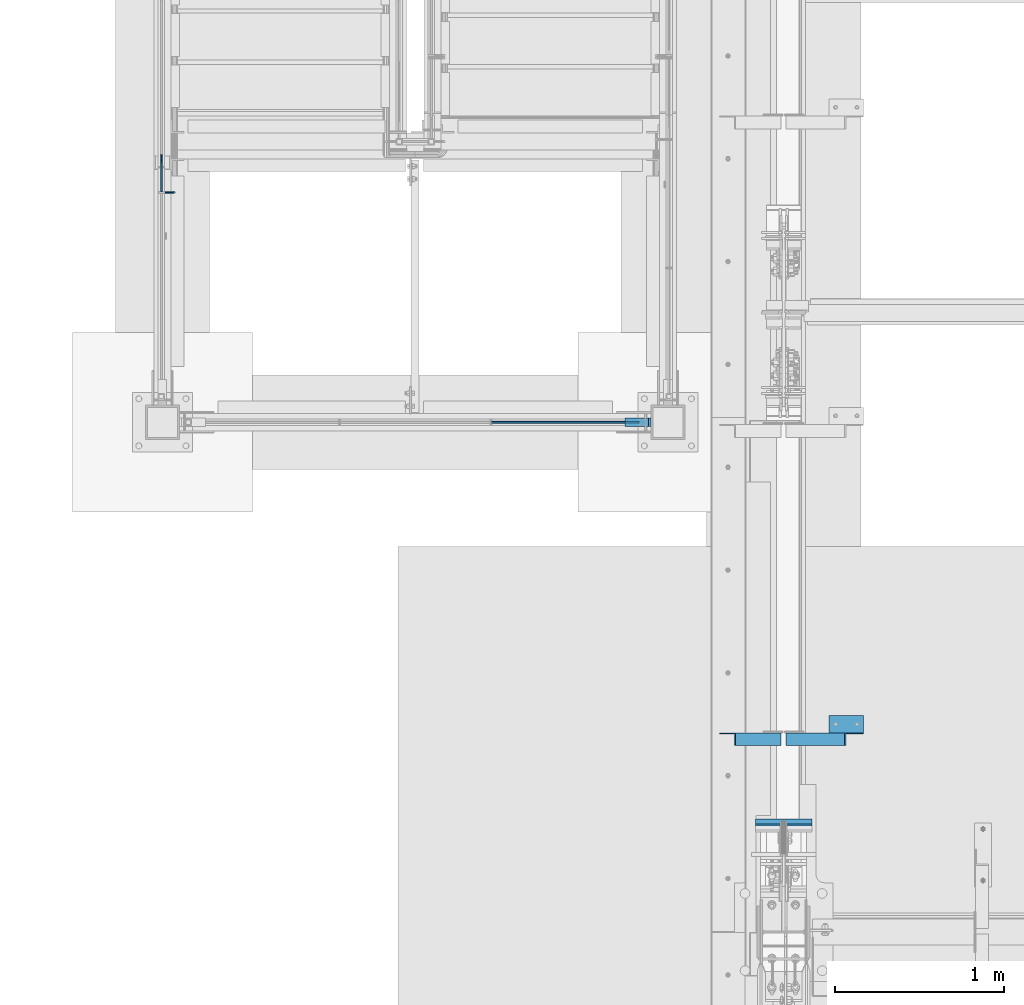
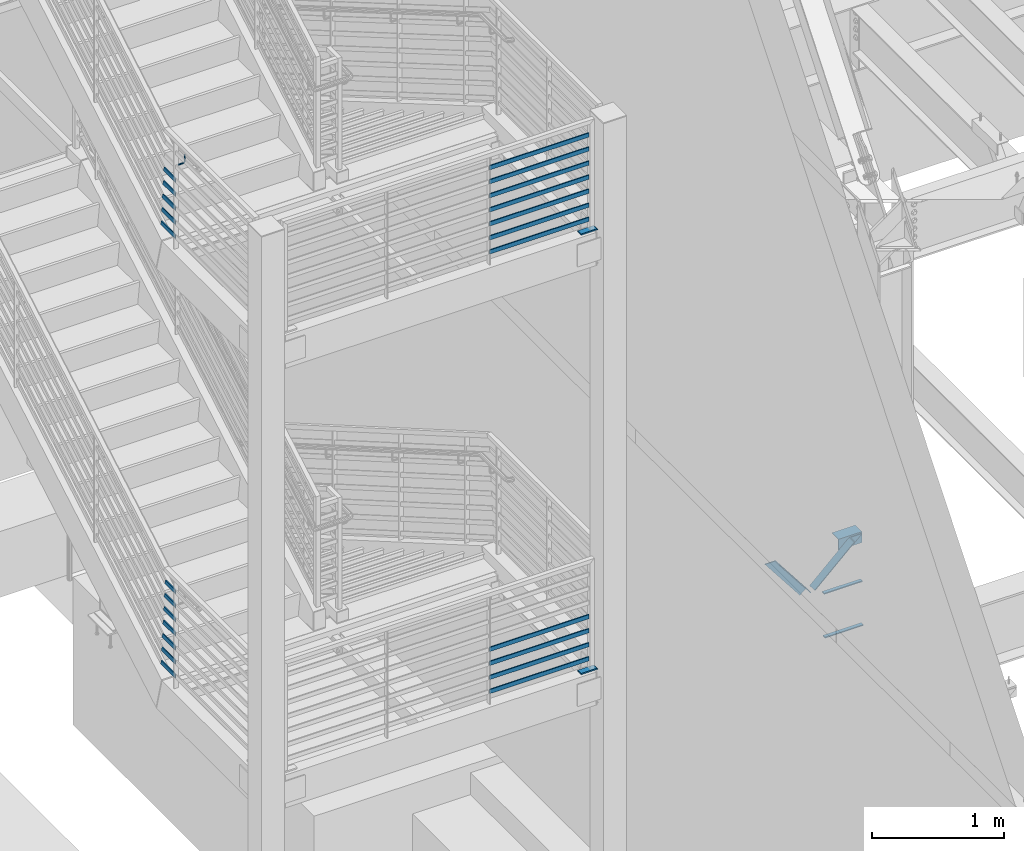
# One storey, part 832 of 1179: 29 beams, 2 members, 10 elements without a shape of their own.
"""IFC2X3 building model written with IfcOpenShell, lengths in millimetres."""

from ifc_helpers import new_model, si_unit, frame, origin_with_axes, place, context, subcontext, project, spatial, faceted_brep, material, type_object, element, aggregate, save


model = new_model("IFC2X3")

# Units and contexts
model_context = context("Model", 3, precision=1e-05, world=origin_with_axes())
body_context = subcontext(model_context, "Body", "Model", "MODEL_VIEW")
ifc_project = project(units=[si_unit("LENGTHUNIT", "METRE", prefix="MILLI"), si_unit("AREAUNIT", "SQUARE_METRE"), si_unit("VOLUMEUNIT", "CUBIC_METRE"), si_unit("MASSUNIT", "GRAM", prefix="KILO"), si_unit("TIMEUNIT", "SECOND"), si_unit("PLANEANGLEUNIT", "RADIAN"), si_unit("SOLIDANGLEUNIT", "STERADIAN"), si_unit("THERMODYNAMICTEMPERATUREUNIT", "DEGREE_CELSIUS"), si_unit("LUMINOUSINTENSITYUNIT", "LUMEN")], contexts=[model_context])

# Site, building, storey
site_placement = place(None, origin_with_axes())
site = spatial("IfcSite", under=ifc_project, at=site_placement, CompositionType="ELEMENT")
building_placement = place(site_placement, origin_with_axes())
building = spatial("IfcBuilding", under=site, at=building_placement, Name="Undefined", CompositionType="ELEMENT")
storey_placement = place(building_placement, origin_with_axes())
storey = spatial("IfcBuildingStorey", under=building, at=storey_placement, Name="Undefined", CompositionType="ELEMENT", Elevation=0.0)

# Assembly, beam
assembly_1_placement = place(storey_placement, origin_with_axes())
assembly_1 = element("IfcElementAssembly", 1, at=assembly_1_placement, inside=storey, Name="PLATE", AssemblyPlace="NOTDEFINED", PredefinedType="RIGID_FRAME")
ifc_material_1 = material(Name="STEEL/A572-GR.50")
beam_type_1 = type_object("IfcBeamType", PredefinedType="NOTDEFINED")
beam_1_placement = place(assembly_1_placement, frame((-507.999999999998, 30073.6, 2174.875), z_axis=(0.0, 1.0, 0.0), x_axis=(1.0, 0.0, 0.0)))
beam_1 = element("IfcBeam", 2, at=beam_1_placement, type_object=beam_type_1, material=ifc_material_1, Name="PLATE", context=body_context, shape_type="Brep", body=[
    faceted_brep([(152.399999999998, 6.35000000000036, 25.4000000000015), (139.699999999998, -6.35000000000036, 25.4000000000015), (139.699999999998, -6.35000000000036, -25.4000000000015), (152.399999999998, 6.35000000000036, -25.4000000000015), (0.0, -6.35000000000036, -25.4000000000015), (0.0, -6.35000000000036, 25.4000000000015), (0.0, 6.35000000000036, 25.4000000000015), (0.0, 6.35000000000036, -25.4000000000015)], [[[0, 1, 2, 3]], [[4, 5, 6, 7]], [[7, 6, 0, 3]], [[4, 7, 3, 2]], [[5, 4, 2, 1]], [[6, 5, 1, 0]]]),
])
aggregate(assembly_1, [beam_1])

assembly_2_placement = place(storey_placement, origin_with_axes())
assembly_2 = element("IfcElementAssembly", 3, at=assembly_2_placement, inside=storey, Name="PLATE", AssemblyPlace="NOTDEFINED", PredefinedType="RIGID_FRAME")
beam_2_placement = place(assembly_2_placement, frame((-507.999999999998, 30073.6, 6248.4), z_axis=(0.0, 1.0, 0.0), x_axis=(1.0, 0.0, 0.0)))
beam_2 = element("IfcBeam", 4, at=beam_2_placement, type_object=beam_type_1, material=ifc_material_1, Name="PLATE", context=body_context, shape_type="Brep", body=[
    faceted_brep([(152.399999999998, 6.35000000000036, 25.4000000000015), (139.699999999998, -6.35000000000036, 25.4000000000015), (139.699999999998, -6.35000000000036, -25.4000000000015), (152.399999999998, 6.35000000000036, -25.4000000000015), (0.0, -6.35000000000036, -25.4000000000015), (0.0, -6.35000000000036, 25.4000000000015), (0.0, 6.35000000000036, 25.4000000000015), (0.0, 6.35000000000036, -25.4000000000015)], [[[0, 1, 2, 3]], [[4, 5, 6, 7]], [[7, 6, 0, 3]], [[4, 7, 3, 2]], [[5, 4, 2, 1]], [[6, 5, 1, 0]]]),
])
aggregate(assembly_2, [beam_2])

assembly_3_placement = place(storey_placement, origin_with_axes())
assembly_3 = element("IfcElementAssembly", 5, at=assembly_3_placement, inside=storey, Name="GUARDRAIL", AssemblyPlace="NOTDEFINED", PredefinedType="RIGID_FRAME")
ifc_material_2 = material(Name="STEEL/A36")
beam_type_2 = type_object("IfcBeamType", PredefinedType="NOTDEFINED")
beam_3_placement = place(assembly_3_placement, frame((-3238.5000060417, 31436.7333342762, 7010.39999999552), z_axis=(0.0, 0.0, 1.0), x_axis=(1.0, 0.0, 0.0)))
beam_3 = element("IfcBeam", 6, at=beam_3_placement, type_object=beam_type_2, material=ifc_material_2, Name="BRACKET", context=body_context, shape_type="Brep", body=[
    faceted_brep([(0.0, -4.49012806053361, 4.49012806053452), (0.0, 0.0, 6.34999999999991), (0.0, 4.49012806053361, 4.49012806053452), (0.0, 6.34999999999854, 0.0), (0.0, 4.49012806053361, -4.49012806053452), (0.0, 0.0, -6.34999999999991), (0.0, -4.49012806053361, -4.49012806053452), (0.0, -6.34999999999854, 0.0), (44.4500031699827, 0.0, -6.34999999999991), (44.4500031699827, -4.49012806053361, -4.49012806053452), (44.4500031699827, -6.34999999999854, 2.19733919948339e-09), (44.4500031699827, -4.49012806053361, 4.49012806053452), (44.4500031699827, 0.0, 6.34999999999991), (44.4500031699827, 4.49012806053361, 4.49012806053452), (44.4500031699827, 6.34999999999854, 0.0), (44.4500031699827, 4.49012806053361, -4.49012806053452), (53.0450671075391, 4.4901280570557, -2.18708762112465), (53.97500307462, -4.32919478043914e-09, -3.79778396764459), (53.0450671022344, -4.49012806401151, -2.1870876194389), (50.8000030708674, -6.35000000142099, 1.70147734757802), (48.5549390416977, -4.4901280599006, 5.59004231389645), (47.6250030746168, 1.48793333210051e-09, 7.20073866041594), (48.5549390470023, 4.49012806117025, 5.5900423122107), (50.8000030783693, 6.34999999857973, 1.70147734519378), (55.4485256393576, 6.34999999469437, 6.34999990618098), (59.337090604122, 4.49012805180246, 4.10493587545716), (51.5599606707875, 4.49012805866005, 8.59506393599531), (49.9492643188311, -4.54747350886464e-10, 9.52499990463002), (51.5599606615996, -4.4901280624108, 8.59506393379797), (55.4485256263639, -6.35000000530636, 6.34999990307369), (59.337090594938, -4.49012806926839, 4.10493587326664), (60.9477869468905, -1.0153598850593e-08, 3.17499990462466), (61.6401310450869, 4.49012804462109, 12.6999998130159), (63.5000029792477, -1.81098585017025e-08, 12.6999998092651), (57.1500029867496, 6.3499999893902, 12.6999998145698), (52.6598749240178, 4.49012805522943, 12.6999998130159), (50.8000029792477, -3.10683390125632e-09, 12.6999998092651), (52.6598749134085, -4.49012806583778, 12.6999998055144), (57.1500029739432, -6.35000001061053, 12.6999998039605), (61.6401310344776, -4.49012807644976, 12.6999998055144), (63.5000029792478, -6.94672053214163e-08, 76.1999999999989), (61.6401310356729, -4.49012812829824, 76.1999999999989), (57.1500029739432, -6.3500000636559, 76.1999999999989), (52.6598749146037, -4.49012812008004, 76.1999999999989), (50.8000029792478, -5.78438630327582e-08, 76.1999999999989), (52.6598749228227, 4.49012800098717, 76.1999999999989), (57.1500029850595, 6.34999993634483, 76.1999999999989), (61.6401310438919, 4.49012799276898, 76.1999999999989)], [[[0, 1, 2, 3, 4, 5, 6, 7]], [[6, 5, 8, 9]], [[7, 6, 9, 10]], [[0, 7, 10, 11]], [[1, 0, 11, 12]], [[2, 1, 12, 13]], [[3, 2, 13, 14]], [[4, 3, 14, 15]], [[5, 4, 15, 8]], [[8, 15, 16, 17]], [[9, 8, 17, 18]], [[10, 9, 18, 19]], [[11, 10, 19, 20]], [[12, 11, 20, 21]], [[13, 12, 21, 22]], [[14, 13, 22, 23]], [[15, 14, 23, 16]], [[23, 24, 25, 16]], [[22, 26, 24, 23]], [[21, 27, 26, 22]], [[20, 28, 27, 21]], [[19, 29, 28, 20]], [[18, 30, 29, 19]], [[17, 31, 30, 18]], [[16, 25, 31, 17]], [[25, 32, 33, 31]], [[24, 34, 32, 25]], [[26, 35, 34, 24]], [[27, 36, 35, 26]], [[28, 37, 36, 27]], [[29, 38, 37, 28]], [[30, 39, 38, 29]], [[31, 33, 39, 30]], [[39, 33, 40, 41]], [[38, 39, 41, 42]], [[37, 38, 42, 43]], [[36, 37, 43, 44]], [[35, 36, 44, 45]], [[34, 35, 45, 46]], [[32, 34, 46, 47]], [[33, 32, 47, 40]], [[46, 45, 44, 43, 42, 41, 40, 47]]]),
])

# Assembly, beams
assembly_4_placement = place(storey_placement, origin_with_axes())
assembly_4 = element("IfcElementAssembly", 7, at=assembly_4_placement, inside=storey, Name="GUARDRAIL", AssemblyPlace="NOTDEFINED", PredefinedType="RIGID_FRAME")
beam_type_3 = type_object("IfcBeamType", PredefinedType="NOTDEFINED")
beam_4_placement = place(assembly_4_placement, frame((-1303.86666666667, 30073.6, 6350.05291795201), z_axis=(0.0, 0.0, 1.0), x_axis=(1.0, 0.0, 0.0)))
beam_4 = element("IfcBeam", 8, at=beam_4_placement, type_object=beam_type_3, material=ifc_material_2, Name="PLATE", context=body_context, shape_type="Brep", body=[
    faceted_brep([(4.76250000197615, 4.76249999999999, -19.0500000000002), (4.76250000197615, 4.76249999999999, 19.0500000000002), (878.416667431667, 4.76249999999709, 19.0499999999993), (878.416667431667, 4.76249999999709, -19.0499999999993), (4.76250000197615, -4.76249999999999, 19.0500000000002), (878.416667431667, -4.76249999999709, 19.0499999999993), (4.76250000197615, -4.76249999999999, -19.0500000000002), (878.416667431667, -4.76249999999709, -19.0499999999993)], [[[0, 1, 2, 3]], [[1, 4, 5, 2]], [[4, 6, 7, 5]], [[6, 0, 3, 7]], [[5, 7, 3, 2]], [[6, 4, 1, 0]]]),
])
beam_5_placement = place(assembly_4_placement, frame((-1303.86666666667, 30073.6, 6480.22791840516), z_axis=(0.0, 0.0, 1.0), x_axis=(1.0, 0.0, 0.0)))
beam_5 = element("IfcBeam", 9, at=beam_5_placement, type_object=beam_type_3, material=ifc_material_2, Name="PLATE", context=body_context, shape_type="Brep", body=[
    faceted_brep([(4.76250000197615, 4.76249999999999, -19.0500000000002), (4.76250000197615, 4.76249999999999, 19.0500000000002), (878.416667431667, 4.76249999999709, 19.0499999999993), (878.416667431667, 4.76249999999709, -19.0499999999993), (4.76250000197615, -4.76249999999999, 19.0500000000002), (878.416667431667, -4.76249999999709, 19.0499999999993), (4.76250000197615, -4.76249999999999, -19.0500000000002), (878.416667431667, -4.76249999999709, -19.0499999999993)], [[[0, 1, 2, 3]], [[1, 4, 5, 2]], [[4, 6, 7, 5]], [[6, 0, 3, 7]], [[5, 7, 3, 2]], [[6, 4, 1, 0]]]),
])
beam_6_placement = place(assembly_4_placement, frame((-1303.86666666667, 30073.6, 6610.40291796448), z_axis=(0.0, 0.0, 1.0), x_axis=(1.0, 0.0, 0.0)))
beam_6 = element("IfcBeam", 10, at=beam_6_placement, type_object=beam_type_3, material=ifc_material_2, Name="PLATE", context=body_context, shape_type="Brep", body=[
    faceted_brep([(4.76250000197615, 4.76249999999999, -19.0500000000002), (4.76250000197615, 4.76249999999999, 19.0500000000002), (878.416667431667, 4.76249999999709, 19.0499999999993), (878.416667431667, 4.76249999999709, -19.0499999999993), (4.76250000197615, -4.76249999999999, 19.0500000000002), (878.416667431667, -4.76249999999709, 19.0499999999993), (4.76250000197615, -4.76249999999999, -19.0500000000002), (878.416667431667, -4.76249999999709, -19.0499999999993)], [[[0, 1, 2, 3]], [[1, 4, 5, 2]], [[4, 6, 7, 5]], [[6, 0, 3, 7]], [[5, 7, 3, 2]], [[6, 4, 1, 0]]]),
])
beam_7_placement = place(assembly_4_placement, frame((-1303.86666666667, 30073.6, 6740.57791897761), z_axis=(0.0, 0.0, 1.0), x_axis=(1.0, 0.0, 0.0)))
beam_7 = element("IfcBeam", 11, at=beam_7_placement, type_object=beam_type_3, material=ifc_material_2, Name="PLATE", context=body_context, shape_type="Brep", body=[
    faceted_brep([(4.76250000197615, 4.76249999999999, -19.0500000000002), (4.76250000197615, 4.76249999999999, 19.0500000000002), (878.416667431667, 4.76249999999709, 19.0499999999993), (878.416667431667, 4.76249999999709, -19.0499999999993), (4.76250000197615, -4.76249999999999, 19.0500000000002), (878.416667431667, -4.76249999999709, 19.0499999999993), (4.76250000197615, -4.76249999999999, -19.0500000000002), (878.416667431667, -4.76249999999709, -19.0499999999993)], [[[0, 1, 2, 3]], [[1, 4, 5, 2]], [[4, 6, 7, 5]], [[6, 0, 3, 7]], [[5, 7, 3, 2]], [[6, 4, 1, 0]]]),
])
beam_8_placement = place(assembly_4_placement, frame((-1303.86666666667, 30073.6, 6870.75291897588), z_axis=(0.0, 0.0, 1.0), x_axis=(1.0, 0.0, 0.0)))
beam_8 = element("IfcBeam", 12, at=beam_8_placement, type_object=beam_type_3, material=ifc_material_2, Name="PLATE", context=body_context, shape_type="Brep", body=[
    faceted_brep([(4.76250000197615, 4.76249999999999, -19.0500000000002), (4.76250000197615, 4.76249999999999, 19.0500000000002), (878.416667431667, 4.76249999999709, 19.0499999999993), (878.416667431667, 4.76249999999709, -19.0499999999993), (4.76250000197615, -4.76249999999999, 19.0500000000002), (878.416667431667, -4.76249999999709, 19.0499999999993), (4.76250000197615, -4.76249999999999, -19.0500000000002), (878.416667431667, -4.76249999999709, -19.0499999999993)], [[[0, 1, 2, 3]], [[1, 4, 5, 2]], [[4, 6, 7, 5]], [[6, 0, 3, 7]], [[5, 7, 3, 2]], [[6, 4, 1, 0]]]),
])
beam_9_placement = place(assembly_4_placement, frame((-1303.86666666667, 30073.6, 7000.92791897937), z_axis=(0.0, 0.0, 1.0), x_axis=(1.0, 0.0, 0.0)))
beam_9 = element("IfcBeam", 13, at=beam_9_placement, type_object=beam_type_3, material=ifc_material_2, Name="PLATE", context=body_context, shape_type="Brep", body=[
    faceted_brep([(4.76250000197615, 4.76249999999999, -19.0500000000002), (4.76250000197615, 4.76249999999999, 19.0500000000002), (878.416667431667, 4.76249999999709, 19.0499999999993), (878.416667431667, 4.76249999999709, -19.0499999999993), (4.76250000197615, -4.76249999999999, 19.0500000000002), (878.416667431667, -4.76249999999709, 19.0499999999993), (4.76250000197615, -4.76249999999999, -19.0500000000002), (878.416667431667, -4.76249999999709, -19.0499999999993)], [[[0, 1, 2, 3]], [[1, 4, 5, 2]], [[4, 6, 7, 5]], [[6, 0, 3, 7]], [[5, 7, 3, 2]], [[6, 4, 1, 0]]]),
])
beam_10_placement = place(assembly_4_placement, frame((-1303.86666666667, 30073.6, 7131.10291897937), z_axis=(0.0, 0.0, 1.0), x_axis=(1.0, 0.0, 0.0)))
beam_10 = element("IfcBeam", 14, at=beam_10_placement, type_object=beam_type_3, material=ifc_material_2, Name="PLATE", context=body_context, shape_type="Brep", body=[
    faceted_brep([(4.76250000197615, 4.76249999999999, -19.0500000000002), (4.76250000197615, 4.76249999999999, 19.0500000000002), (878.416667431667, 4.76249999999709, 19.0499999999993), (878.416667431667, 4.76249999999709, -19.0499999999993), (4.76250000197615, -4.76249999999999, 19.0500000000002), (878.416667431667, -4.76249999999709, 19.0499999999993), (4.76250000197615, -4.76249999999999, -19.0500000000002), (878.416667431667, -4.76249999999709, -19.0499999999993)], [[[0, 1, 2, 3]], [[1, 4, 5, 2]], [[4, 6, 7, 5]], [[6, 0, 3, 7]], [[5, 7, 3, 2]], [[6, 4, 1, 0]]]),
])
aggregate(assembly_4, [beam_4, beam_5, beam_6, beam_7, beam_8, beam_9, beam_10])

# Beam
beam_11_placement = place(assembly_3_placement, frame((-3257.54999923555, 31660.4888003087, 6349.99999993336), z_axis=(0.0, 0.0, 1.0), x_axis=(0.0, -1.0, 0.0)))
beam_11 = element("IfcBeam", 15, at=beam_11_placement, type_object=beam_type_3, material=ifc_material_2, Name="PLATE", context=body_context, shape_type="Brep", body=[
    faceted_brep([(-1.58237177445335, 4.76249999999982, -19.0500000000002), (8.71746487778728, 4.76249999999982, 19.0500000000002), (218.992966975384, 4.76249999999982, 19.0500000000002), (218.992966975384, 4.76249999999982, -19.0500000000002), (8.71746487778728, -4.76249999999982, 19.0500000000002), (218.992966975384, -4.76249999999982, 19.0500000000002), (-1.58237177445335, -4.76249999999982, -19.0500000000002), (218.992966975384, -4.76249999999982, -19.0500000000002)], [[[0, 1, 2, 3]], [[1, 4, 5, 2]], [[4, 6, 7, 5]], [[6, 0, 3, 7]], [[5, 7, 3, 2]], [[6, 4, 1, 0]]]),
])

beam_12_placement = place(assembly_3_placement, frame((-3257.54999923555, 31649.6033755532, 6480.1252855965), z_axis=(0.0, 0.0, 1.0), x_axis=(0.0, -1.0, 0.0)))
beam_12 = element("IfcBeam", 16, at=beam_12_placement, type_object=beam_type_3, material=ifc_material_2, Name="PLATE", context=body_context, shape_type="Brep", body=[
    faceted_brep([(-2.08273084649409, 4.76249999999982, -19.0500000000002), (8.21710580574654, 4.76249999999982, 19.0500000000002), (208.107542219892, 4.76249999999982, 19.0500000000002), (208.107542219892, 4.76249999999982, -19.0500000000002), (8.21710580574654, -4.76249999999982, 19.0500000000002), (208.107542219892, -4.76249999999982, 19.0500000000002), (-2.08273084649409, -4.76249999999982, -19.0500000000002), (208.107542219892, -4.76249999999982, -19.0500000000002)], [[[0, 1, 2, 3]], [[1, 4, 5, 2]], [[4, 6, 7, 5]], [[6, 0, 3, 7]], [[5, 7, 3, 2]], [[6, 4, 1, 0]]]),
])

beam_13_placement = place(assembly_3_placement, frame((-3257.54999923555, 31638.7169688553, 6610.31317642902), z_axis=(0.0, 0.0, 1.0), x_axis=(0.0, -1.0, 0.0)))
beam_13 = element("IfcBeam", 17, at=beam_13_placement, type_object=beam_type_3, material=ifc_material_2, Name="PLATE", context=body_context, shape_type="Brep", body=[
    faceted_brep([(-2.69140062553925, 4.76249999999982, -19.0500000000002), (7.60843602670138, 4.76249999999982, 19.0500000000002), (197.221135521973, 4.76249999999982, 19.0500000000002), (197.221135521973, 4.76249999999982, -19.0500000000002), (7.60843602670138, -4.76249999999982, 19.0500000000002), (197.221135521973, -4.76249999999982, 19.0500000000002), (-2.69140062553925, -4.76249999999982, -19.0500000000002), (197.221135521973, -4.76249999999982, -19.0500000000002)], [[[0, 1, 2, 3]], [[1, 4, 5, 2]], [[4, 6, 7, 5]], [[6, 0, 3, 7]], [[5, 7, 3, 2]], [[6, 4, 1, 0]]]),
])

beam_14_placement = place(assembly_3_placement, frame((-3257.54999923555, 31627.8305624375, 6740.50828692898), z_axis=(0.0, 0.0, 1.0), x_axis=(0.0, -1.0, 0.0)))
beam_14 = element("IfcBeam", 18, at=beam_14_placement, type_object=beam_type_3, material=ifc_material_2, Name="PLATE", context=body_context, shape_type="Brep", body=[
    faceted_brep([(-3.31244734500069, 4.76249999999982, -19.0500000000002), (6.98738930723994, 4.76249999999982, 19.0500000000002), (186.334729104165, 4.76249999999982, 19.0500000000002), (186.334729104165, 4.76249999999982, -19.0500000000002), (6.98738930723994, -4.76249999999982, 19.0500000000002), (186.334729104165, -4.76249999999982, 19.0500000000002), (-3.31244734500069, -4.76249999999982, -19.0500000000002), (186.334729104165, -4.76249999999982, -19.0500000000002)], [[[0, 1, 2, 3]], [[1, 4, 5, 2]], [[4, 6, 7, 5]], [[6, 0, 3, 7]], [[5, 7, 3, 2]], [[6, 4, 1, 0]]]),
])

beam_15_placement = place(assembly_3_placement, frame((-3257.54999923555, 31616.944156247, 6870.70925595739), z_axis=(0.0, 0.0, 1.0), x_axis=(0.0, -1.0, 0.0)))
beam_15 = element("IfcBeam", 19, at=beam_15_placement, type_object=beam_type_3, material=ifc_material_2, Name="PLATE", context=body_context, shape_type="Brep", body=[
    faceted_brep([(-3.94353755444172, 4.76249999999982, -19.0500000000002), (6.35629909779891, 4.76249999999982, 19.0500000000002), (175.448322913624, 4.76249999999982, 19.0500000000002), (175.448322913624, 4.76249999999982, -19.0500000000002), (6.35629909779891, -4.76249999999982, 19.0500000000002), (175.448322913624, -4.76249999999982, 19.0500000000002), (-3.94353755444172, -4.76249999999982, -19.0500000000002), (175.448322913624, -4.76249999999982, -19.0500000000002)], [[[0, 1, 2, 3]], [[1, 4, 5, 2]], [[4, 6, 7, 5]], [[6, 0, 3, 7]], [[5, 7, 3, 2]], [[6, 4, 1, 0]]]),
])

aggregate(assembly_3, [beam_3, beam_11, beam_12, beam_13, beam_14, beam_15])

# Assembly, beams
assembly_5_placement = place(storey_placement, origin_with_axes())
assembly_5 = element("IfcElementAssembly", 20, at=assembly_5_placement, inside=storey, Name="GUARDRAIL", AssemblyPlace="NOTDEFINED", PredefinedType="RIGID_FRAME")
beam_16_placement = place(assembly_5_placement, frame((-1303.86666666667, 30073.6, 2276.52791764178), z_axis=(0.0, 0.0, 1.0), x_axis=(1.0, 0.0, 0.0)))
beam_16 = element("IfcBeam", 21, at=beam_16_placement, type_object=beam_type_3, material=ifc_material_2, Name="PLATE", context=body_context, shape_type="Brep", body=[
    faceted_brep([(4.76250000197615, 4.76249999999999, -19.0500000000002), (4.76250000197615, 4.76249999999999, 19.0500000000002), (878.416667431667, 4.76249999999709, 19.0499999999993), (878.416667431667, 4.76249999999709, -19.0499999999993), (4.76250000197615, -4.76249999999999, 19.0500000000002), (878.416667431667, -4.76249999999709, 19.0499999999993), (4.76250000197615, -4.76249999999999, -19.0500000000002), (878.416667431667, -4.76249999999709, -19.0499999999993)], [[[0, 1, 2, 3]], [[1, 4, 5, 2]], [[4, 6, 7, 5]], [[6, 0, 3, 7]], [[5, 7, 3, 2]], [[6, 4, 1, 0]]]),
])
beam_17_placement = place(assembly_5_placement, frame((-1303.86666666667, 30073.6, 2406.70291809494), z_axis=(0.0, 0.0, 1.0), x_axis=(1.0, 0.0, 0.0)))
beam_17 = element("IfcBeam", 22, at=beam_17_placement, type_object=beam_type_3, material=ifc_material_2, Name="PLATE", context=body_context, shape_type="Brep", body=[
    faceted_brep([(4.76250000197615, 4.76249999999999, -19.0500000000002), (4.76250000197615, 4.76249999999999, 19.0500000000002), (878.416667431667, 4.76249999999709, 19.0499999999993), (878.416667431667, 4.76249999999709, -19.0499999999993), (4.76250000197615, -4.76249999999999, 19.0500000000002), (878.416667431667, -4.76249999999709, 19.0499999999993), (4.76250000197615, -4.76249999999999, -19.0500000000002), (878.416667431667, -4.76249999999709, -19.0499999999993)], [[[0, 1, 2, 3]], [[1, 4, 5, 2]], [[4, 6, 7, 5]], [[6, 0, 3, 7]], [[5, 7, 3, 2]], [[6, 4, 1, 0]]]),
])
beam_18_placement = place(assembly_5_placement, frame((-1303.86666666667, 30073.6, 2536.87791765425), z_axis=(0.0, 0.0, 1.0), x_axis=(1.0, 0.0, 0.0)))
beam_18 = element("IfcBeam", 23, at=beam_18_placement, type_object=beam_type_3, material=ifc_material_2, Name="PLATE", context=body_context, shape_type="Brep", body=[
    faceted_brep([(4.76250000197615, 4.76249999999999, -19.0500000000002), (4.76250000197615, 4.76249999999999, 19.0500000000002), (878.416667431667, 4.76249999999709, 19.0499999999993), (878.416667431667, 4.76249999999709, -19.0499999999993), (4.76250000197615, -4.76249999999999, 19.0500000000002), (878.416667431667, -4.76249999999709, 19.0499999999993), (4.76250000197615, -4.76249999999999, -19.0500000000002), (878.416667431667, -4.76249999999709, -19.0499999999993)], [[[0, 1, 2, 3]], [[1, 4, 5, 2]], [[4, 6, 7, 5]], [[6, 0, 3, 7]], [[5, 7, 3, 2]], [[6, 4, 1, 0]]]),
])
beam_19_placement = place(assembly_5_placement, frame((-1303.86666666667, 30073.6, 2667.05291866739), z_axis=(0.0, 0.0, 1.0), x_axis=(1.0, 0.0, 0.0)))
beam_19 = element("IfcBeam", 24, at=beam_19_placement, type_object=beam_type_3, material=ifc_material_2, Name="PLATE", context=body_context, shape_type="Brep", body=[
    faceted_brep([(4.76250000197615, 4.76249999999999, -19.0500000000002), (4.76250000197615, 4.76249999999999, 19.0500000000002), (878.416667431667, 4.76249999999709, 19.0499999999993), (878.416667431667, 4.76249999999709, -19.0499999999993), (4.76250000197615, -4.76249999999999, 19.0500000000002), (878.416667431667, -4.76249999999709, 19.0499999999993), (4.76250000197615, -4.76249999999999, -19.0500000000002), (878.416667431667, -4.76249999999709, -19.0499999999993)], [[[0, 1, 2, 3]], [[1, 4, 5, 2]], [[4, 6, 7, 5]], [[6, 0, 3, 7]], [[5, 7, 3, 2]], [[6, 4, 1, 0]]]),
])
aggregate(assembly_5, [beam_16, beam_17, beam_18, beam_19])

assembly_6_placement = place(storey_placement, origin_with_axes())
assembly_6 = element("IfcElementAssembly", 25, at=assembly_6_placement, inside=storey, Name="GUARDRAIL", AssemblyPlace="NOTDEFINED", PredefinedType="RIGID_FRAME")
beam_20_placement = place(assembly_6_placement, frame((-3257.54999923555, 31660.9935580043, 2276.50679560806), z_axis=(0.0, 0.0, 1.0), x_axis=(0.0, -1.0, 0.0)))
beam_20 = element("IfcBeam", 26, at=beam_20_placement, type_object=beam_type_3, material=ifc_material_2, Name="PLATE", context=body_context, shape_type="Brep", body=[
    faceted_brep([(-0.716409127351653, 4.76249999999982, -19.0500000000002), (9.51759781362125, 4.76249999999982, 19.0500000000002), (219.497724670975, 4.76249999999982, 19.0500000000002), (219.497724670975, 4.76249999999982, -19.0500000000002), (9.51759781362125, -4.76249999999982, 19.0500000000002), (219.497724670975, -4.76249999999982, 19.0500000000002), (-0.716409127351653, -4.76249999999982, -19.0500000000002), (219.497724670975, -4.76249999999982, -19.0500000000002)], [[[0, 1, 2, 3]], [[1, 4, 5, 2]], [[4, 6, 7, 5]], [[6, 0, 3, 7]], [[5, 7, 3, 2]], [[6, 4, 1, 0]]]),
])
beam_21_placement = place(assembly_6_placement, frame((-3257.54999923555, 31650.0262416665, 2406.68179560661), z_axis=(0.0, 0.0, 1.0), x_axis=(0.0, -1.0, 0.0)))
beam_21 = element("IfcBeam", 27, at=beam_21_placement, type_object=beam_type_3, material=ifc_material_2, Name="PLATE", context=body_context, shape_type="Brep", body=[
    faceted_brep([(-1.44971849846479, 4.76249999999982, -19.0500000000002), (8.78428844250448, 4.76249999999982, 19.0500000000002), (208.530408333132, 4.76249999999982, 19.0500000000002), (208.530408333132, 4.76249999999982, -19.0500000000002), (8.78428844250448, -4.76249999999982, 19.0500000000002), (208.530408333132, -4.76249999999982, 19.0500000000002), (-1.44971849846479, -4.76249999999982, -19.0500000000002), (208.530408333132, -4.76249999999982, -19.0500000000002)], [[[0, 1, 2, 3]], [[1, 4, 5, 2]], [[4, 6, 7, 5]], [[6, 0, 3, 7]], [[5, 7, 3, 2]], [[6, 4, 1, 0]]]),
])
beam_22_placement = place(assembly_6_placement, frame((-3257.54999923555, 31639.0589253135, 2536.85679560802), z_axis=(0.0, 0.0, 1.0), x_axis=(0.0, -1.0, 0.0)))
beam_22 = element("IfcBeam", 28, at=beam_22_placement, type_object=beam_type_3, material=ifc_material_2, Name="PLATE", context=body_context, shape_type="Brep", body=[
    faceted_brep([(-2.18302788969595, 4.76249999999982, -19.0500000000002), (8.05097905127695, 4.76249999999982, 19.0500000000002), (197.563091980126, 4.76249999999982, 19.0500000000002), (197.563091980126, 4.76249999999982, -19.0500000000002), (8.05097905127695, -4.76249999999982, 19.0500000000002), (197.563091980126, -4.76249999999982, 19.0500000000002), (-2.18302788969595, -4.76249999999982, -19.0500000000002), (197.563091980126, -4.76249999999982, -19.0500000000002)], [[[0, 1, 2, 3]], [[1, 4, 5, 2]], [[4, 6, 7, 5]], [[6, 0, 3, 7]], [[5, 7, 3, 2]], [[6, 4, 1, 0]]]),
])
beam_23_placement = place(assembly_6_placement, frame((-3257.54999923555, 31628.0916089725, 2667.03179560715), z_axis=(0.0, 0.0, 1.0), x_axis=(0.0, -1.0, 0.0)))
beam_23 = element("IfcBeam", 29, at=beam_23_placement, type_object=beam_type_3, material=ifc_material_2, Name="PLATE", context=body_context, shape_type="Brep", body=[
    faceted_brep([(-2.91633726494547, 4.76249999999982, -19.0500000000002), (7.31766967602744, 4.76249999999982, 19.0500000000002), (186.595775639147, 4.76249999999982, 19.0500000000002), (186.595775639147, 4.76249999999982, -19.0500000000002), (7.31766967602744, -4.76249999999982, 19.0500000000002), (186.595775639147, -4.76249999999982, 19.0500000000002), (-2.91633726494547, -4.76249999999982, -19.0500000000002), (186.595775639147, -4.76249999999982, -19.0500000000002)], [[[0, 1, 2, 3]], [[1, 4, 5, 2]], [[4, 6, 7, 5]], [[6, 0, 3, 7]], [[5, 7, 3, 2]], [[6, 4, 1, 0]]]),
])
beam_24_placement = place(assembly_6_placement, frame((-3257.54999923555, 31617.1242926287, 2797.20679560579), z_axis=(0.0, 0.0, 1.0), x_axis=(0.0, -1.0, 0.0)))
beam_24 = element("IfcBeam", 30, at=beam_24_placement, type_object=beam_type_3, material=ifc_material_2, Name="PLATE", context=body_context, shape_type="Brep", body=[
    faceted_brep([(-3.6496466421122, 4.76249999999982, -19.0500000000002), (6.5843602988607, 4.76249999999982, 19.0500000000002), (175.628459295411, 4.76249999999982, 19.0500000000002), (175.628459295411, 4.76249999999982, -19.0500000000002), (6.5843602988607, -4.76249999999982, 19.0500000000002), (175.628459295411, -4.76249999999982, 19.0500000000002), (-3.6496466421122, -4.76249999999982, -19.0500000000002), (175.628459295411, -4.76249999999982, -19.0500000000002)], [[[0, 1, 2, 3]], [[1, 4, 5, 2]], [[4, 6, 7, 5]], [[6, 0, 3, 7]], [[5, 7, 3, 2]], [[6, 4, 1, 0]]]),
])
beam_25_placement = place(assembly_6_placement, frame((-3257.54999923555, 31606.1569762757, 2927.38179560718), z_axis=(0.0, 0.0, 1.0), x_axis=(0.0, -1.0, 0.0)))
beam_25 = element("IfcBeam", 31, at=beam_25_placement, type_object=beam_type_3, material=ifc_material_2, Name="PLATE", context=body_context, shape_type="Brep", body=[
    faceted_brep([(-4.38295603333609, 4.76249999999982, -19.0500000000002), (5.85105090763318, 4.76249999999982, 19.0500000000002), (164.661142942376, 4.76249999999982, 19.0500000000002), (164.661142942376, 4.76249999999982, -19.0500000000002), (5.85105090763318, -4.76249999999982, 19.0500000000002), (164.661142942376, -4.76249999999982, 19.0500000000002), (-4.38295603333609, -4.76249999999982, -19.0500000000002), (164.661142942376, -4.76249999999982, -19.0500000000002)], [[[0, 1, 2, 3]], [[1, 4, 5, 2]], [[4, 6, 7, 5]], [[6, 0, 3, 7]], [[5, 7, 3, 2]], [[6, 4, 1, 0]]]),
])
beam_26_placement = place(assembly_6_placement, frame((-3257.54999923555, 31595.1896599524, 3057.5567956159), z_axis=(0.0, 0.0, 1.0), x_axis=(0.0, -1.0, 0.0)))
beam_26 = element("IfcBeam", 32, at=beam_26_placement, type_object=beam_type_3, material=ifc_material_2, Name="PLATE", context=body_context, shape_type="Brep", body=[
    faceted_brep([(-5.11626540751604, 4.76249999999982, -19.0500000000002), (5.11774153345686, 4.76249999999982, 19.0500000000002), (153.693826619045, 4.76249999999982, 19.0500000000002), (153.693826619045, 4.76249999999982, -19.0500000000002), (5.11774153345686, -4.76249999999982, 19.0500000000002), (153.693826619045, -4.76249999999982, 19.0500000000002), (-5.11626540751604, -4.76249999999982, -19.0500000000002), (153.693826619045, -4.76249999999982, -19.0500000000002)], [[[0, 1, 2, 3]], [[1, 4, 5, 2]], [[4, 6, 7, 5]], [[6, 0, 3, 7]], [[5, 7, 3, 2]], [[6, 4, 1, 0]]]),
])
aggregate(assembly_6, [beam_20, beam_21, beam_22, beam_23, beam_24, beam_25, beam_26])

# Assembly, member
assembly_7_placement = place(storey_placement, origin_with_axes())
assembly_7 = element("IfcElementAssembly", 33, at=assembly_7_placement, inside=storey, Name="ANGLE", AssemblyPlace="NOTDEFINED", PredefinedType="RIGID_FRAME")
member_type = type_object("IfcMemberType", Name="L3X3X1/4", PredefinedType="NOTDEFINED")
member_1_placement = place(assembly_7_placement, frame((472.414639168566, 28194.0, 3736.19330123132), z_axis=(0.0, -1.0, 0.0), x_axis=(0.729484494811633, 0.0, 0.683997347823379)))
member_1 = element("IfcMember", 34, at=member_1_placement, type_object=member_type, material=ifc_material_2, Name="ANGLE", ObjectType="L3X3X1/4", context=body_context, shape_type="Brep", body=[
    faceted_brep([(0.0, 38.0999999999985, -38.0999999999999), (0.0, 38.0999999999985, 38.0999999999999), (475.752341075195, 38.0999999999181, 38.1000000000004), (475.752341075195, 38.0999999999181, -38.1000000000004), (0.0, 31.75, 38.1000000000004), (482.524628360803, 31.7499999999177, 38.1000000000004), (0.0, 31.75, -31.75), (482.524628360803, 31.7499999999177, -31.75), (0.0, -38.0999999999985, -31.75), (557.019788502486, -38.1000000000854, -31.75), (0.0, -38.0999999999985, -38.0999999999999), (557.019788502486, -38.1000000000854, -38.1000000000004)], [[[0, 1, 2, 3]], [[1, 4, 5, 2]], [[4, 6, 7, 5]], [[6, 8, 9, 7]], [[8, 10, 11, 9]], [[10, 0, 3, 11]], [[5, 7, 9, 11, 3, 2]], [[10, 8, 6, 4, 1, 0]]]),
])
aggregate(assembly_7, [member_1])

assembly_8_placement = place(storey_placement, origin_with_axes())
assembly_8 = element("IfcElementAssembly", 35, at=assembly_8_placement, inside=storey, Name="ANGLE", AssemblyPlace="NOTDEFINED", PredefinedType="RIGID_FRAME")
member_2_placement = place(assembly_8_placement, frame((80.8196258456501, 28194.0, 4125.56128839178), z_axis=(0.0, -1.0, 0.0), x_axis=(0.614083067285056, 0.0, -0.789241399366364)))
member_2 = element("IfcMember", 36, at=member_2_placement, type_object=member_type, material=ifc_material_2, Name="ANGLE", ObjectType="L3X3X1/4", context=body_context, shape_type="Brep", body=[
    faceted_brep([(59.3707492954454, 38.0999999999781, -38.1000000000004), (59.3707492954454, 38.0999999999781, 38.1000000000004), (499.083854779058, 38.0999999998585, 38.1000000000004), (499.083854779058, 38.0999999998585, -38.1000000000004), (54.4300207928691, 31.7499999999804, 38.1000000000004), (499.083854779056, 31.7499999998595, 38.1000000000004), (54.4300207928691, 31.7499999999804, -31.75), (499.083854779056, 31.7499999998595, -31.75), (0.0820072645328764, -38.0999999999945, -31.75), (499.083854779043, -38.10000000013, -31.75), (0.0820072645328764, -38.0999999999945, -38.1000000000004), (499.083854779043, -38.10000000013, -38.1000000000004)], [[[0, 1, 2, 3]], [[1, 4, 5, 2]], [[4, 6, 7, 5]], [[6, 8, 9, 7]], [[8, 10, 11, 9]], [[10, 0, 3, 11]], [[5, 7, 9, 11, 3, 2]], [[10, 8, 6, 4, 1, 0]]]),
])
aggregate(assembly_8, [member_2])

# Assembly, beams
assembly_9_placement = place(storey_placement, origin_with_axes())
assembly_9 = element("IfcElementAssembly", 37, at=assembly_9_placement, inside=storey, Name="BEAM", AssemblyPlace="NOTDEFINED", PredefinedType="RIGID_FRAME")
beam_type_4 = type_object("IfcBeamType", PredefinedType="NOTDEFINED")
beam_27_placement = place(assembly_9_placement, frame((431.800036620873, 27679.8709035276, 3678.2375), z_axis=(-1.0, 0.0, 0.0), x_axis=(0.0, 1.0, 0.0)))
beam_27 = element("IfcBeam", 38, at=beam_27_placement, type_object=beam_type_4, material=ifc_material_1, Name="PLATE", context=body_context, shape_type="Brep", body=[
    faceted_brep([(0.0, 4.76249999999982, -168.275000000001), (0.0, 4.76250000000073, 168.275), (31.75, 4.76249999999982, 168.275000000001), (31.75, 4.76249999999982, -168.275000000001), (0.0, -4.76250000000073, 168.275), (31.75, -4.76249999999982, 168.275000000001), (0.0, -4.76249999999982, -168.275000000001), (31.75, -4.76249999999982, -168.275000000001)], [[[0, 1, 2, 3]], [[1, 4, 5, 2]], [[4, 6, 7, 5]], [[6, 0, 3, 7]], [[5, 7, 3, 2]], [[6, 4, 1, 0]]]),
])
beam_28_placement = place(assembly_9_placement, frame((431.800036620873, 27690.983001131, 4077.8905), z_axis=(-1.0, 0.0, 0.0), x_axis=(0.0, 1.0, 0.0)))
beam_28 = element("IfcBeam", 39, at=beam_28_placement, type_object=beam_type_4, material=ifc_material_1, Name="PLATE", context=body_context, shape_type="Brep", body=[
    faceted_brep([(0.0, 4.76249999999982, -168.275000000001), (0.0, 4.76250000000073, 168.275), (31.75, 4.76249999999982, 168.275000000001), (31.75, 4.76249999999982, -168.275000000001), (0.0, -4.76250000000073, 168.275), (31.75, -4.76249999999982, 168.275000000001), (0.0, -4.76249999999982, -168.275000000001), (31.75, -4.76249999999982, -168.275000000001)], [[[0, 1, 2, 3]], [[1, 4, 5, 2]], [[4, 6, 7, 5]], [[6, 0, 3, 7]], [[5, 7, 3, 2]], [[6, 4, 1, 0]]]),
])
aggregate(assembly_9, [beam_27, beam_28])

# Assembly, beam
assembly_10_placement = place(storey_placement, origin_with_axes())
assembly_10 = element("IfcElementAssembly", 40, at=assembly_10_placement, inside=storey, Name="ANGLE", AssemblyPlace="NOTDEFINED", PredefinedType="RIGID_FRAME")
beam_type_5 = type_object("IfcBeamType", Name="L4X4X1/4", PredefinedType="NOTDEFINED")
beam_29_placement = place(assembly_10_placement, frame((701.596355341565, 28282.9, 4051.3), z_axis=(0.0, 0.0, -1.0), x_axis=(1.0, 0.0, 0.0)))
beam_29 = element("IfcBeam", 41, at=beam_29_placement, type_object=beam_type_5, material=ifc_material_2, Name="ANGLE", ObjectType="L4X4X1/4", context=body_context, shape_type="Brep", body=[
    faceted_brep([(1.90993887372315e-11, 50.8000000000002, -50.8000000000002), (1.90993887372315e-11, 50.8000000000002, 50.8000000000002), (203.200000000001, 50.7999999999993, 50.8000000000002), (203.200000000001, 50.7999999999993, -50.8000000000002), (0.0, 44.4500000000007, 50.8000000000002), (203.200000000001, 44.4500000000007, 50.8000000000002), (0.0, 44.4500000000007, -44.4499999999998), (203.200000000001, 44.4500000000007, -44.4499999999998), (0.0, -50.7999999999993, -44.4499999999998), (203.200000000001, -50.7999999999993, -44.4499999999998), (-1.81898940354586e-11, -50.7999999999997, -50.8000000000002), (203.200000000001, -50.7999999999993, -50.8000000000002)], [[[0, 1, 2, 3]], [[1, 4, 5, 2]], [[4, 6, 7, 5]], [[6, 8, 9, 7]], [[8, 10, 11, 9]], [[10, 0, 3, 11]], [[5, 7, 9, 11, 3, 2]], [[10, 8, 6, 4, 1, 0]]]),
])
aggregate(assembly_10, [beam_29])

save(model, "model.ifc")
